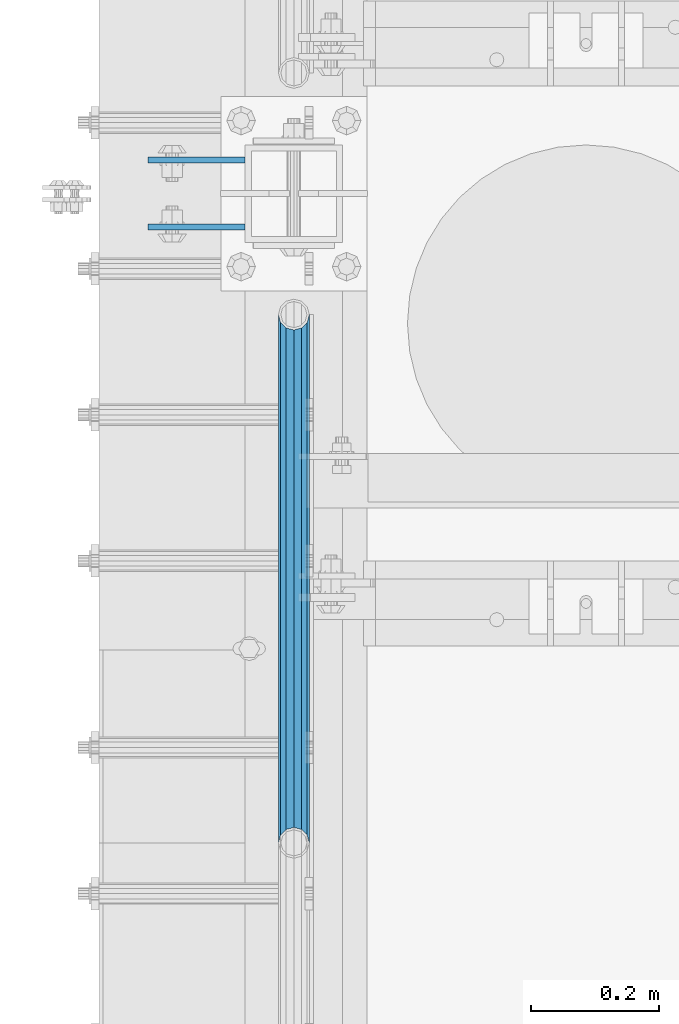
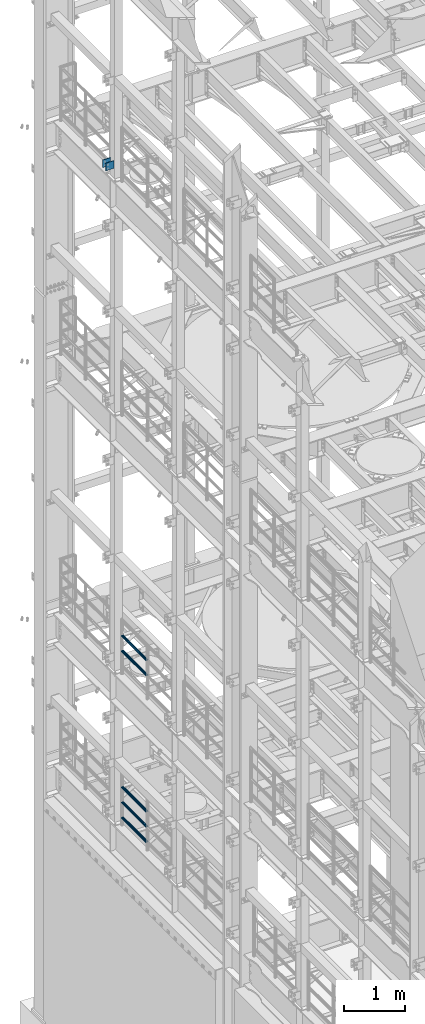
# One storey, part 1307 of 1876: 7 beams, 3 elements without a shape of their own.
"""IFC2X3 building model written with IfcOpenShell, lengths in millimetres."""

import ifcopenshell
import ifcopenshell.guid

model = None  # the IFC model being written
_history = None  # IfcOwnerHistory: only IFC2X3 demands one
_inside = {}  # id of a spatial element -> (the spatial element, [elements in it])
_under = {}  # id of a project, library or spatial element -> (it, [spatial elements below it])
_declared = {}  # id of a project -> (the project, [libraries it declares])
_typed = {}  # id of a type object -> (the type object, [elements of that type])
_made_of = {}  # id of a material, layer set ... -> (it, [elements and type objects made of it])


def new_model(schema):
    """Start an empty IFC model of exactly this schema.

    Asked for "IFC4X3", IfcOpenShell would pick the latest addendum, in which some entities
    have other attributes; the version numbers below select the first issue.
    IFC2X3 requires an IfcOwnerHistory on every rooted entity: one is made here for all.
    """
    global model, _history
    if schema == "IFC4X3":
        model = ifcopenshell.file(schema_version=(4, 3, 0, 0))
    else:
        model = ifcopenshell.file(schema=schema)
    _inside.clear()
    _under.clear()
    _declared.clear()
    _typed.clear()
    _made_of.clear()
    _history = None
    if model.schema == "IFC2X3":
        org = make("IfcOrganization", Name="unknown")
        user = make(
            "IfcPersonAndOrganization",
            ThePerson=make("IfcPerson", FamilyName="unknown"),
            TheOrganization=org,
        )
        app = make(
            "IfcApplication",
            ApplicationDeveloper=org,
            Version="unknown",
            ApplicationFullName="unknown",
            ApplicationIdentifier="unknown",
        )
        _history = make(
            "IfcOwnerHistory",
            OwningUser=user,
            OwningApplication=app,
            ChangeAction="ADDED",
            CreationDate=0,
        )
    return model


def make(cls, **values):
    """One entity of the class cls with the attributes given. An attribute that is None is left unset."""
    return model.create_entity(
        cls, **{name: value for name, value in values.items() if value is not None}
    )


def rooted(cls, **values):
    """An entity with a GlobalId (a new one), such as an element, a storey or a relation."""
    return make(cls, GlobalId=ifcopenshell.guid.new(), OwnerHistory=_history, **values)


def si_unit(unit_type, name, prefix=None):
    """IfcSIUnit, for example si_unit("LENGTHUNIT", "METRE", prefix="MILLI")."""
    return make("IfcSIUnit", UnitType=unit_type, Prefix=prefix, Name=name)


def assignment(units):
    """IfcUnitAssignment: the units of a project."""
    return None if units is None else make("IfcUnitAssignment", Units=units)


def point(xyz):
    """IfcCartesianPoint."""
    return None if xyz is None else make("IfcCartesianPoint", Coordinates=xyz)


def direction(xyz):
    """IfcDirection."""
    return None if xyz is None else make("IfcDirection", DirectionRatios=xyz)


def frame(location, z_axis=None, x_axis=None):
    """IfcAxis2Placement3D, a coordinate frame: its origin and axes. An axis left out is left unset."""
    return make(
        "IfcAxis2Placement3D",
        Location=point(location),
        Axis=direction(z_axis),
        RefDirection=direction(x_axis),
    )


def origin_with_axes():
    """The frame at (0, 0, 0) with the z axis (0, 0, 1) and the x axis (1, 0, 0) written out."""
    return frame((0.0, 0.0, 0.0), z_axis=(0.0, 0.0, 1.0), x_axis=(1.0, 0.0, 0.0))


def place(relative_to, where):
    """IfcLocalPlacement: puts the frame where relative to a parent placement (None: the world)."""
    return make(
        "IfcLocalPlacement", PlacementRelTo=relative_to, RelativePlacement=where
    )


def context(
    kind, dimensions, precision=None, world=None, true_north=None, identifier=None
):
    """IfcGeometricRepresentationContext, for example the 3D "Model" context."""
    return make(
        "IfcGeometricRepresentationContext",
        ContextIdentifier=identifier,
        ContextType=kind,
        CoordinateSpaceDimension=dimensions,
        Precision=precision,
        WorldCoordinateSystem=world,
        TrueNorth=true_north,
    )


def subcontext(parent, identifier, kind, view, scale=None):
    """IfcGeometricRepresentationSubContext, for example "Body" below "Model"."""
    return make(
        "IfcGeometricRepresentationSubContext",
        ContextIdentifier=identifier,
        ContextType=kind,
        ParentContext=parent,
        TargetScale=scale,
        TargetView=view,
    )


def project(units=None, contexts=None):
    """IfcProject with its units and contexts."""
    return rooted(
        "IfcProject",
        Name="project",
        RepresentationContexts=contexts,
        UnitsInContext=assignment(units),
    )


def spatial(cls, under=None, at=None, **own):
    """A site, building, storey or space (cls), placed at a placement, below another one or the project."""
    s = rooted(cls, ObjectPlacement=at, **own)
    if under is not None:
        _under.setdefault(under.id(), (under, []))[1].append(s)
    return s


def faces_of(points, faces, orient=None, outer=None):
    """IfcFace entities. A face is a list of loops; a loop is a list of indices into points, from 0.

    orient and outer hold one flag for each loop. By default every Orientation is true, the
    first loop of a face is its IfcFaceOuterBound and the others are IfcFaceBound.
    """
    made = []
    for i, loops in enumerate(faces):
        bounds = []
        for j, loop in enumerate(loops):
            is_outer = j == 0 if outer is None else outer[i][j]
            bounds.append(
                make(
                    "IfcFaceOuterBound" if is_outer else "IfcFaceBound",
                    Bound=make("IfcPolyLoop", Polygon=[points[k] for k in loop]),
                    Orientation=True if orient is None else orient[i][j],
                )
            )
        made.append(make("IfcFace", Bounds=bounds))
    return made


def faceted_brep(points, faces, orient=None, outer=None, voids=None):
    """IfcFacetedBrep: a solid bounded by flat faces; with voids (closed shells), ...WithVoids."""
    shared = [point(p) for p in points]
    hull = make("IfcClosedShell", CfsFaces=faces_of(shared, faces, orient, outer))
    if voids is None:
        return make("IfcFacetedBrep", Outer=hull)
    return make(
        "IfcFacetedBrepWithVoids",
        Outer=hull,
        Voids=[
            make(cls, CfsFaces=faces_of(shared, fs, o, b)) for cls, fs, o, b in voids
        ],
    )


def shape(context_of_items, identifier, shape_type, items):
    """IfcShapeRepresentation: the items that make up one representation, for example the "Body"."""
    return make(
        "IfcShapeRepresentation",
        ContextOfItems=context_of_items,
        RepresentationIdentifier=identifier,
        RepresentationType=shape_type,
        Items=items,
    )


def material(Name=None, Category=None):
    """IfcMaterial."""
    return make("IfcMaterial", Name=Name, Category=Category)


def made_of(thing, what):
    """Note that an element or type object is made of a material, layer set ...; save() writes the relation."""
    if what is not None:
        _made_of.setdefault(what.id(), (what, []))[1].append(thing)
    return thing


def type_object(cls, material=None, **own):
    """A type object (cls), such as IfcWallType, which elements share."""
    return made_of(rooted(cls, **own), material)


def element(
    cls,
    number,
    at=None,
    inside=None,
    cuts=None,
    type_object=None,
    material=None,
    context=None,
    identifier="Body",
    shape_type=None,
    held_by="IfcProductDefinitionShape",
    body=None,
    shapes=None,
    **own,
):
    """One element of the class cls, such as IfcWall. Its Tag is "e" and its number.

    at: its placement. inside: the storey or other place that contains it. cuts: it is an
    opening in that element (IfcRelVoidsElement). A single representation is given by context,
    identifier, shape_type and body (its items); several are given by shapes. held_by: the class
    of the entity that holds the representations. save() writes the other relations.
    """
    e = rooted(cls, Tag="e%d" % number, ObjectPlacement=at, **own)
    if body is not None:
        shapes = [shape(context, identifier, shape_type, body)]
    if shapes is not None:
        e.Representation = make(held_by, Representations=shapes)
    if inside is not None:
        _inside.setdefault(inside.id(), (inside, []))[1].append(e)
    if cuts is not None:
        rooted(
            "IfcRelVoidsElement", RelatingBuildingElement=cuts, RelatedOpeningElement=e
        )
    if type_object is not None:
        _typed.setdefault(type_object.id(), (type_object, []))[1].append(e)
    return made_of(e, material)


def aggregate(whole, parts):
    """IfcRelAggregates: a whole, such as a stair, and the parts it consists of."""
    return rooted("IfcRelAggregates", RelatingObject=whole, RelatedObjects=parts)


def save(model, path):
    """Write the relations noted so far, then the file.

    IfcRelAggregates (storeys below a building ...), IfcRelContainedInSpatialStructure (elements
    in a storey), IfcRelDefinesByType, IfcRelAssociatesMaterial and IfcRelDeclares: one each for
    every whole, place, type object, material and project.
    """
    for whole, parts in _under.values():
        aggregate(whole, parts)
    for where, things in _inside.values():
        rooted(
            "IfcRelContainedInSpatialStructure",
            RelatedElements=things,
            RelatingStructure=where,
        )
    for kind, things in _typed.values():
        rooted("IfcRelDefinesByType", RelatedObjects=things, RelatingType=kind)
    for what, things in _made_of.values():
        rooted("IfcRelAssociatesMaterial", RelatedObjects=things, RelatingMaterial=what)
    for by, libraries in _declared.values():
        rooted("IfcRelDeclares", RelatingContext=by, RelatedDefinitions=libraries)
    model.write(path)


model = new_model("IFC2X3")

# Units and contexts
model_context = context("Model", 3, precision=1e-05, world=origin_with_axes())
body_context = subcontext(model_context, "Body", "Model", "MODEL_VIEW")
ifc_project = project(units=[si_unit("LENGTHUNIT", "METRE", prefix="MILLI"), si_unit("AREAUNIT", "SQUARE_METRE"), si_unit("VOLUMEUNIT", "CUBIC_METRE"), si_unit("MASSUNIT", "GRAM", prefix="KILO"), si_unit("TIMEUNIT", "SECOND"), si_unit("PLANEANGLEUNIT", "RADIAN"), si_unit("SOLIDANGLEUNIT", "STERADIAN"), si_unit("THERMODYNAMICTEMPERATUREUNIT", "DEGREE_CELSIUS"), si_unit("LUMINOUSINTENSITYUNIT", "LUMEN")], contexts=[model_context])

# Site, building, storey
site_placement = place(None, origin_with_axes())
site = spatial("IfcSite", under=ifc_project, at=site_placement, CompositionType="ELEMENT")
building_placement = place(site_placement, origin_with_axes())
building = spatial("IfcBuilding", under=site, at=building_placement, Name="Undefined", CompositionType="ELEMENT")
storey_placement = place(building_placement, origin_with_axes())
storey = spatial("IfcBuildingStorey", under=building, at=storey_placement, Name="Undefined", CompositionType="ELEMENT", Elevation=0.0)

# Assembly, beams
assembly_1_placement = place(storey_placement, origin_with_axes())
assembly_1 = element("IfcElementAssembly", 1, at=assembly_1_placement, inside=storey, Name="BEAM", AssemblyPlace="NOTDEFINED", PredefinedType="RIGID_FRAME")
ifc_material_1 = material(Name="STEEL/A36")
beam_type_1 = type_object("IfcBeamType", PredefinedType="NOTDEFINED")
beam_1_placement = place(assembly_1_placement, frame((-76.2000002548894, 11736.3875, 18275.3), z_axis=(0.0, 0.0, -1.0), x_axis=(-1.0, 0.0, 0.0)))
beam_1 = element("IfcBeam", 2, at=beam_1_placement, type_object=beam_type_1, material=ifc_material_1, Name="PLATE", context=body_context, shape_type="Brep", body=[
    faceted_brep([(0.0, 4.76249999999982, -76.1999999999998), (3.63797880709171e-12, 4.76249999999982, 76.1999969482422), (152.399993896484, 4.76250000000073, 76.1999969482422), (152.4, 4.76249999999982, -76.1999999999998), (3.63797880709171e-12, -4.76249999999982, 76.1999969482422), (152.399993896484, -4.76250000000073, 76.1999969482422), (0.0, -4.76249999999982, -76.1999999999998), (152.4, -4.76249999999982, -76.1999999999998)], [[[0, 1, 2, 3]], [[4, 5, 2, 1]], [[4, 6, 7, 5]], [[6, 0, 3, 7]], [[5, 7, 3, 2]], [[6, 4, 1, 0]]]),
])
beam_2_placement = place(assembly_1_placement, frame((-76.2000002548894, 11631.6125, 18275.3), z_axis=(0.0, 0.0, -1.0), x_axis=(-1.0, 0.0, 0.0)))
beam_2 = element("IfcBeam", 3, at=beam_2_placement, type_object=beam_type_1, material=ifc_material_1, Name="PLATE", context=body_context, shape_type="Brep", body=[
    faceted_brep([(0.0, 4.76249999999982, -76.1999999999998), (3.63797880709171e-12, 4.76249999999982, 76.1999969482422), (152.399993896484, 4.76250000000073, 76.1999969482422), (152.4, 4.76249999999982, -76.1999999999998), (3.63797880709171e-12, -4.76249999999982, 76.1999969482422), (152.399993896484, -4.76250000000073, 76.1999969482422), (0.0, -4.76249999999982, -76.1999999999998), (152.4, -4.76249999999982, -76.1999999999998)], [[[0, 1, 2, 3]], [[4, 5, 2, 1]], [[4, 6, 7, 5]], [[6, 0, 3, 7]], [[5, 7, 3, 2]], [[6, 4, 1, 0]]]),
])
aggregate(assembly_1, [beam_1, beam_2])

assembly_2_placement = place(storey_placement, origin_with_axes())
assembly_2 = element("IfcElementAssembly", 4, at=assembly_2_placement, inside=storey, Name="RAIL", AssemblyPlace="NOTDEFINED", PredefinedType="RIGID_FRAME")
ifc_material_2 = material()
beam_type_2 = type_object("IfcBeamType", Name="PIPE1-1/2SCH40", PredefinedType="NOTDEFINED")
beam_3_placement = place(assembly_2_placement, frame((-1.81898940354586e-12, 10668.0, 8620.125), z_axis=(0.0, 0.0, -1.0), x_axis=(0.0, 1.0, 0.0)))
beam_3 = element("IfcBeam", 5, at=beam_3_placement, type_object=beam_type_2, material=ifc_material_2, Name="RAIL", ObjectType="PIPE1-1/2SCH40", context=body_context, shape_type="Brep", body=[
    faceted_brep([(0.0, 24.1299999999992, 0.0), (12.0650000000064, 20.8971929933177, -12.0649999999987), (12.0650000000064, 20.8971929933177, 12.0649999999987), (12.0650000000064, -20.8971929933177, 12.0649999999987), (12.0650000000064, -20.8971929933177, -12.0649999999987), (0.0, -24.1299999999992, 0.0), (20.8971929933249, -12.0650000000005, 20.8971929933177), (20.8971929933249, -12.0650000000005, 15.8661214311796), (15.2545715621445, -17.7076214311801, 10.2235000000001), (12.5151929933249, -20.4470000000001, 0.0), (15.2545715621445, -17.7076214311801, -10.2235000000001), (20.8971929933249, -12.0650000000005, -15.8661214311796), (20.8971929933249, -12.0650000000005, -20.8971929933177), (24.1300000000063, 0.0, -20.4470000000001), (24.1300000000063, 0.0, -24.130000000001), (21.3906214311868, -10.2235000000001, -17.7076214311819), (21.3906214311868, 10.2235000000001, -17.7076214311819), (20.8971929933249, 12.0650000000005, -15.8661214311796), (20.8971929933249, 12.0650000000005, -20.8971929933177), (15.2545715621445, 17.7076214311801, -10.2235000000001), (12.5151929933249, 20.4470000000001, 0.0), (15.2545715621445, 17.7076214311801, 10.2235000000001), (20.8971929933249, 12.0650000000005, 15.8661214311796), (20.8971929933249, 12.0650000000005, 20.8971929933177), (21.3906214311868, 10.2235000000001, 17.7076214311819), (24.1300000000064, 0.0, 20.4470000000001), (24.1300000000064, 0.0, 24.130000000001), (21.3906214311868, -10.2235000000001, 17.7076214311819), (826.77, 24.1300000000001, 0.0), (814.705, 20.8971929933186, -12.0649999999987), (805.872807006681, 12.0649999999996, -20.8971929933177), (826.77, -24.1300000000001, 0.0), (814.705, -20.8971929933186, -12.0649999999987), (814.705, -20.8971929933186, 12.0649999999987), (805.872807006681, -12.0649999999996, 20.8971929933177), (805.872807006681, -12.0649999999996, -20.8971929933177), (802.640000000001, 0.0, -24.130000000001), (805.379378568819, 10.2235000000001, -17.7076214311819), (802.640000000001, 0.0, -20.4470000000001), (805.872807006683, 12.0649999999996, -15.8661214311796), (805.872807006683, -12.0649999999996, -15.8661214311796), (805.379378568819, -10.2235000000001, -17.7076214311819), (811.515428437862, -17.7076214311801, -10.2235000000001), (814.254807006682, -20.4470000000001, 0.0), (811.515428437862, -17.7076214311801, 10.2235000000001), (805.872807006683, -12.0649999999996, 15.8661214311796), (805.379378568819, -10.2235000000001, 17.7076214311819), (802.640000000001, 0.0, 20.4470000000001), (802.640000000001, 0.0, 24.130000000001), (805.872807006681, 12.0649999999996, 20.8971929933177), (814.705, 20.8971929933186, 12.0649999999987), (805.872807006683, 12.0649999999996, 15.8661214311796), (811.515428437862, 17.7076214311801, 10.2235000000001), (814.254807006682, 20.4470000000001, 0.0), (811.515428437862, 17.7076214311801, -10.2235000000001), (805.379378568819, 10.2235000000001, 17.7076214311819)], [[[0, 1, 2]], [[3, 4, 5]], [[6, 7, 8, 9, 10, 11, 12, 4, 3]], [[13, 14, 12, 11, 15]], [[16, 17, 18, 14, 13]], [[2, 1, 18, 17, 19, 20, 21, 22, 23]], [[23, 22, 24, 25, 26]], [[26, 25, 27, 7, 6]], [[1, 0, 28, 29]], [[18, 1, 29, 30]], [[31, 32, 33]], [[6, 3, 33, 34]], [[3, 5, 31, 33]], [[5, 4, 32, 31]], [[4, 12, 35, 32]], [[12, 14, 36, 35]], [[14, 18, 30, 36]], [[37, 38, 36, 30, 39]], [[40, 35, 36, 38, 41]], [[33, 32, 35, 40, 42, 43, 44, 45, 34]], [[34, 45, 46, 47, 48]], [[26, 6, 34, 48]], [[2, 23, 49, 50]], [[23, 26, 48, 49]], [[0, 2, 50, 28]], [[28, 50, 29]], [[49, 51, 52, 53, 54, 39, 30, 29, 50]], [[48, 47, 55, 51, 49]], [[25, 24, 55, 47]], [[55, 24, 22, 21, 52, 51]], [[21, 20, 53, 52]], [[20, 19, 54, 53]], [[19, 17, 16, 37, 39, 54]], [[16, 13, 38, 37]], [[13, 15, 41, 38]], [[41, 15, 11, 10, 42, 40]], [[10, 9, 43, 42]], [[9, 8, 44, 43]], [[8, 7, 27, 46, 45, 44]], [[27, 25, 47, 46]]]),
])
beam_4_placement = place(assembly_2_placement, frame((-1.81898940354586e-12, 10668.0, 8924.925), z_axis=(0.0, 0.0, -1.0), x_axis=(0.0, 1.0, 0.0)))
beam_4 = element("IfcBeam", 6, at=beam_4_placement, type_object=beam_type_2, material=ifc_material_2, Name="RAIL", ObjectType="PIPE1-1/2SCH40", context=body_context, shape_type="Brep", body=[
    faceted_brep([(0.0, 24.1299999999992, 0.0), (12.0650000000064, 20.8971929933177, -12.0649999999987), (12.0650000000064, 20.8971929933177, 12.0649999999987), (12.0650000000064, -20.8971929933177, 12.0649999999987), (12.0650000000064, -20.8971929933177, -12.0649999999987), (0.0, -24.1299999999992, 0.0), (20.8971929933249, -12.0650000000005, 20.8971929933177), (20.8971929933249, -12.0650000000005, 15.8661214311796), (15.2545715621445, -17.7076214311801, 10.2235000000001), (12.5151929933249, -20.4470000000001, 0.0), (15.2545715621445, -17.7076214311801, -10.2235000000001), (20.8971929933249, -12.0650000000005, -15.8661214311796), (20.8971929933249, -12.0650000000005, -20.8971929933177), (24.1300000000063, 0.0, -20.4470000000001), (24.1300000000063, 0.0, -24.130000000001), (21.3906214311868, -10.2235000000001, -17.7076214311819), (21.3906214311868, 10.2235000000001, -17.7076214311819), (20.8971929933249, 12.0650000000005, -15.8661214311796), (20.8971929933249, 12.0650000000005, -20.8971929933177), (15.2545715621445, 17.7076214311801, -10.2235000000001), (12.5151929933249, 20.4470000000001, 0.0), (15.2545715621445, 17.7076214311801, 10.2235000000001), (20.8971929933249, 12.0650000000005, 15.8661214311796), (20.8971929933249, 12.0650000000005, 20.8971929933177), (21.3906214311868, 10.2235000000001, 17.7076214311819), (24.1300000000064, 0.0, 20.4470000000001), (24.1300000000064, 0.0, 24.130000000001), (21.3906214311868, -10.2235000000001, 17.7076214311819), (826.77, 24.1300000000001, 0.0), (814.705, 20.8971929933186, -12.0649999999987), (805.872807006681, 12.0649999999996, -20.8971929933177), (826.77, -24.1300000000001, 0.0), (814.705, -20.8971929933186, -12.0649999999987), (814.705, -20.8971929933186, 12.0649999999987), (805.872807006681, -12.0649999999996, 20.8971929933177), (805.872807006681, -12.0649999999996, -20.8971929933177), (802.640000000001, 0.0, -24.130000000001), (805.379378568819, 10.2235000000001, -17.7076214311819), (802.640000000001, 0.0, -20.4470000000001), (805.872807006683, 12.0649999999996, -15.8661214311796), (805.872807006683, -12.0649999999996, -15.8661214311796), (805.379378568819, -10.2235000000001, -17.7076214311819), (811.515428437862, -17.7076214311801, -10.2235000000001), (814.254807006682, -20.4470000000001, 0.0), (811.515428437862, -17.7076214311801, 10.2235000000001), (805.872807006683, -12.0649999999996, 15.8661214311796), (805.379378568819, -10.2235000000001, 17.7076214311819), (802.640000000001, 0.0, 20.4470000000001), (802.640000000001, 0.0, 24.130000000001), (805.872807006681, 12.0649999999996, 20.8971929933177), (814.705, 20.8971929933186, 12.0649999999987), (805.872807006683, 12.0649999999996, 15.8661214311796), (811.515428437862, 17.7076214311801, 10.2235000000001), (814.254807006682, 20.4470000000001, 0.0), (811.515428437862, 17.7076214311801, -10.2235000000001), (805.379378568819, 10.2235000000001, 17.7076214311819)], [[[0, 1, 2]], [[3, 4, 5]], [[6, 7, 8, 9, 10, 11, 12, 4, 3]], [[13, 14, 12, 11, 15]], [[16, 17, 18, 14, 13]], [[2, 1, 18, 17, 19, 20, 21, 22, 23]], [[23, 22, 24, 25, 26]], [[26, 25, 27, 7, 6]], [[1, 0, 28, 29]], [[18, 1, 29, 30]], [[31, 32, 33]], [[6, 3, 33, 34]], [[3, 5, 31, 33]], [[5, 4, 32, 31]], [[4, 12, 35, 32]], [[12, 14, 36, 35]], [[14, 18, 30, 36]], [[37, 38, 36, 30, 39]], [[40, 35, 36, 38, 41]], [[33, 32, 35, 40, 42, 43, 44, 45, 34]], [[34, 45, 46, 47, 48]], [[26, 6, 34, 48]], [[2, 23, 49, 50]], [[23, 26, 48, 49]], [[0, 2, 50, 28]], [[28, 50, 29]], [[49, 51, 52, 53, 54, 39, 30, 29, 50]], [[48, 47, 55, 51, 49]], [[25, 24, 55, 47]], [[55, 24, 22, 21, 52, 51]], [[21, 20, 53, 52]], [[20, 19, 54, 53]], [[19, 17, 16, 37, 39, 54]], [[16, 13, 38, 37]], [[13, 15, 41, 38]], [[41, 15, 11, 10, 42, 40]], [[10, 9, 43, 42]], [[9, 8, 44, 43]], [[8, 7, 27, 46, 45, 44]], [[27, 25, 47, 46]]]),
])
aggregate(assembly_2, [beam_3, beam_4])

assembly_3_placement = place(storey_placement, origin_with_axes())
assembly_3 = element("IfcElementAssembly", 7, at=assembly_3_placement, inside=storey, Name="RAIL", AssemblyPlace="NOTDEFINED", PredefinedType="RIGID_FRAME")
beam_5_placement = place(assembly_3_placement, frame((-1.81898940354586e-12, 11494.77, 5292.725), z_axis=(0.0, 0.0, 1.0), x_axis=(0.0, -1.0, 0.0)))
beam_5 = element("IfcBeam", 8, at=beam_5_placement, type_object=beam_type_2, material=ifc_material_2, Name="RAIL", ObjectType="PIPE1-1/2SCH40", context=body_context, shape_type="Brep", body=[
    faceted_brep([(805.872807006681, -12.0649999999996, 20.8971929933177), (805.872807006683, -12.0649999999996, 15.8661214311796), (805.379378568819, -10.2235000000001, 17.7076214311819), (802.640000000001, 0.0, 20.4470000000001), (802.640000000001, 0.0, 24.130000000001), (805.379378568819, 10.2235000000001, 17.7076214311819), (805.872807006683, 12.0649999999996, 15.8661214311796), (805.872807006681, 12.0649999999996, 20.8971929933177), (826.77, 24.1300000000001, 0.0), (814.705, 20.8971929933186, 12.0649999999987), (814.705, 20.8971929933186, -12.0649999999987), (811.515428437862, 17.7076214311801, 10.2235000000001), (814.254807006682, 20.4470000000001, 0.0), (811.515428437862, 17.7076214311801, -10.2235000000001), (805.872807006683, 12.0649999999996, -15.8661214311796), (805.872807006681, 12.0649999999996, -20.8971929933177), (805.379378568819, 10.2235000000001, -17.7076214311819), (802.640000000001, 0.0, -20.4470000000001), (802.640000000001, 0.0, -24.130000000001), (805.872807006683, -12.0649999999996, -15.8661214311796), (805.872807006681, -12.0649999999996, -20.8971929933177), (805.379378568819, -10.2235000000001, -17.7076214311819), (826.77, -24.1300000000001, 0.0), (814.705, -20.8971929933186, -12.0649999999987), (814.705, -20.8971929933186, 12.0649999999987), (811.515428437862, -17.7076214311801, -10.2235000000001), (814.254807006682, -20.4470000000001, 0.0), (811.515428437862, -17.7076214311801, 10.2235000000001), (12.0650000000064, -20.8971929933177, -12.0649999999987), (20.8971929933249, -12.0650000000005, -20.8971929933177), (0.0, 24.1299999999992, 0.0), (12.0650000000064, 20.8971929933177, -12.0649999999987), (12.0650000000064, 20.8971929933177, 12.0649999999987), (20.8971929933249, 12.0650000000005, 20.8971929933177), (24.1300000000064, 0.0, 24.130000000001), (20.8971929933249, 12.0650000000005, -20.8971929933177), (24.1300000000063, 0.0, -24.130000000001), (24.1300000000063, 0.0, -20.4470000000001), (20.8971929933249, -12.0650000000005, -15.8661214311796), (21.3906214311868, -10.2235000000001, -17.7076214311819), (21.3906214311868, 10.2235000000001, -17.7076214311819), (20.8971929933249, 12.0650000000005, -15.8661214311796), (15.2545715621445, 17.7076214311801, -10.2235000000001), (12.5151929933249, 20.4470000000001, 0.0), (15.2545715621445, 17.7076214311801, 10.2235000000001), (20.8971929933249, 12.0650000000005, 15.8661214311796), (21.3906214311868, 10.2235000000001, 17.7076214311819), (24.1300000000064, 0.0, 20.4470000000001), (21.3906214311868, -10.2235000000001, 17.7076214311819), (20.8971929933249, -12.0650000000005, 15.8661214311796), (20.8971929933249, -12.0650000000005, 20.8971929933177), (12.0650000000064, -20.8971929933177, 12.0649999999987), (0.0, -24.1299999999992, 0.0), (15.2545715621445, -17.7076214311801, 10.2235000000001), (12.5151929933249, -20.4470000000001, 0.0), (15.2545715621445, -17.7076214311801, -10.2235000000001)], [[[0, 1, 2, 3, 4]], [[4, 3, 5, 6, 7]], [[8, 9, 10]], [[7, 6, 11, 12, 13, 14, 15, 10, 9]], [[16, 17, 18, 15, 14]], [[19, 20, 18, 17, 21]], [[22, 23, 24]], [[24, 23, 20, 19, 25, 26, 27, 1, 0]], [[28, 29, 20, 23]], [[30, 31, 32]], [[33, 34, 4, 7]], [[32, 33, 7, 9]], [[30, 32, 9, 8]], [[31, 30, 8, 10]], [[35, 31, 10, 15]], [[36, 35, 15, 18]], [[29, 36, 18, 20]], [[37, 36, 29, 38, 39]], [[40, 41, 35, 36, 37]], [[32, 31, 35, 41, 42, 43, 44, 45, 33]], [[33, 45, 46, 47, 34]], [[34, 47, 48, 49, 50]], [[34, 50, 0, 4]], [[50, 51, 24, 0]], [[51, 52, 22, 24]], [[52, 28, 23, 22]], [[51, 28, 52]], [[50, 49, 53, 54, 55, 38, 29, 28, 51]], [[55, 54, 26, 25]], [[21, 39, 38, 55, 25, 19]], [[37, 39, 21, 17]], [[40, 37, 17, 16]], [[42, 41, 40, 16, 14, 13]], [[43, 42, 13, 12]], [[44, 43, 12, 11]], [[5, 46, 45, 44, 11, 6]], [[47, 46, 5, 3]], [[48, 47, 3, 2]], [[53, 49, 48, 2, 1, 27]], [[54, 53, 27, 26]]]),
])
beam_6_placement = place(assembly_3_placement, frame((-1.81898940354586e-12, 10668.0, 5597.525), z_axis=(0.0, 0.0, -1.0), x_axis=(0.0, 1.0, 0.0)))
beam_6 = element("IfcBeam", 9, at=beam_6_placement, type_object=beam_type_2, material=ifc_material_2, Name="RAIL", ObjectType="PIPE1-1/2SCH40", context=body_context, shape_type="Brep", body=[
    faceted_brep([(0.0, 24.1299999999992, 0.0), (12.0650000000064, 20.8971929933177, -12.0649999999987), (12.0650000000064, 20.8971929933177, 12.0649999999987), (12.0650000000064, -20.8971929933177, 12.0649999999987), (12.0650000000064, -20.8971929933177, -12.0649999999987), (0.0, -24.1299999999992, 0.0), (20.8971929933249, -12.0650000000005, 20.8971929933177), (20.8971929933249, -12.0650000000005, 15.8661214311796), (15.2545715621445, -17.7076214311801, 10.2235000000001), (12.5151929933249, -20.4470000000001, 0.0), (15.2545715621445, -17.7076214311801, -10.2235000000001), (20.8971929933249, -12.0650000000005, -15.8661214311796), (20.8971929933249, -12.0650000000005, -20.8971929933177), (24.1300000000063, 0.0, -20.4470000000001), (24.1300000000063, 0.0, -24.130000000001), (21.3906214311868, -10.2235000000001, -17.7076214311819), (21.3906214311868, 10.2235000000001, -17.7076214311819), (20.8971929933249, 12.0650000000005, -15.8661214311796), (20.8971929933249, 12.0650000000005, -20.8971929933177), (15.2545715621445, 17.7076214311801, -10.2235000000001), (12.5151929933249, 20.4470000000001, 0.0), (15.2545715621445, 17.7076214311801, 10.2235000000001), (20.8971929933249, 12.0650000000005, 15.8661214311796), (20.8971929933249, 12.0650000000005, 20.8971929933177), (21.3906214311868, 10.2235000000001, 17.7076214311819), (24.1300000000064, 0.0, 20.4470000000001), (24.1300000000064, 0.0, 24.130000000001), (21.3906214311868, -10.2235000000001, 17.7076214311819), (826.77, 24.1300000000001, 0.0), (814.705, 20.8971929933186, -12.0649999999987), (805.872807006681, 12.0649999999996, -20.8971929933177), (826.77, -24.1300000000001, 0.0), (814.705, -20.8971929933186, -12.0649999999987), (814.705, -20.8971929933186, 12.0649999999987), (805.872807006681, -12.0649999999996, 20.8971929933177), (805.872807006681, -12.0649999999996, -20.8971929933177), (802.640000000001, 0.0, -24.130000000001), (805.379378568819, 10.2235000000001, -17.7076214311819), (802.640000000001, 0.0, -20.4470000000001), (805.872807006683, 12.0649999999996, -15.8661214311796), (805.872807006683, -12.0649999999996, -15.8661214311796), (805.379378568819, -10.2235000000001, -17.7076214311819), (811.515428437862, -17.7076214311801, -10.2235000000001), (814.254807006682, -20.4470000000001, 0.0), (811.515428437862, -17.7076214311801, 10.2235000000001), (805.872807006683, -12.0649999999996, 15.8661214311796), (805.379378568819, -10.2235000000001, 17.7076214311819), (802.640000000001, 0.0, 20.4470000000001), (802.640000000001, 0.0, 24.130000000001), (805.872807006681, 12.0649999999996, 20.8971929933177), (814.705, 20.8971929933186, 12.0649999999987), (805.872807006683, 12.0649999999996, 15.8661214311796), (811.515428437862, 17.7076214311801, 10.2235000000001), (814.254807006682, 20.4470000000001, 0.0), (811.515428437862, 17.7076214311801, -10.2235000000001), (805.379378568819, 10.2235000000001, 17.7076214311819)], [[[0, 1, 2]], [[3, 4, 5]], [[6, 7, 8, 9, 10, 11, 12, 4, 3]], [[13, 14, 12, 11, 15]], [[16, 17, 18, 14, 13]], [[2, 1, 18, 17, 19, 20, 21, 22, 23]], [[23, 22, 24, 25, 26]], [[26, 25, 27, 7, 6]], [[1, 0, 28, 29]], [[18, 1, 29, 30]], [[31, 32, 33]], [[6, 3, 33, 34]], [[3, 5, 31, 33]], [[5, 4, 32, 31]], [[4, 12, 35, 32]], [[12, 14, 36, 35]], [[14, 18, 30, 36]], [[37, 38, 36, 30, 39]], [[40, 35, 36, 38, 41]], [[33, 32, 35, 40, 42, 43, 44, 45, 34]], [[34, 45, 46, 47, 48]], [[26, 6, 34, 48]], [[2, 23, 49, 50]], [[23, 26, 48, 49]], [[0, 2, 50, 28]], [[28, 50, 29]], [[49, 51, 52, 53, 54, 39, 30, 29, 50]], [[48, 47, 55, 51, 49]], [[25, 24, 55, 47]], [[55, 24, 22, 21, 52, 51]], [[21, 20, 53, 52]], [[20, 19, 54, 53]], [[19, 17, 16, 37, 39, 54]], [[16, 13, 38, 37]], [[13, 15, 41, 38]], [[41, 15, 11, 10, 42, 40]], [[10, 9, 43, 42]], [[9, 8, 44, 43]], [[8, 7, 27, 46, 45, 44]], [[27, 25, 47, 46]]]),
])
beam_7_placement = place(assembly_3_placement, frame((-1.81898940354586e-12, 10668.0, 5902.325), z_axis=(0.0, 0.0, -1.0), x_axis=(0.0, 1.0, 0.0)))
beam_7 = element("IfcBeam", 10, at=beam_7_placement, type_object=beam_type_2, material=ifc_material_2, Name="RAIL", ObjectType="PIPE1-1/2SCH40", context=body_context, shape_type="Brep", body=[
    faceted_brep([(0.0, 24.1299999999992, 0.0), (12.0650000000064, 20.8971929933177, -12.0649999999987), (12.0650000000064, 20.8971929933177, 12.0649999999987), (12.0650000000064, -20.8971929933177, 12.0649999999987), (12.0650000000064, -20.8971929933177, -12.0649999999987), (0.0, -24.1299999999992, 0.0), (20.8971929933249, -12.0650000000005, 20.8971929933177), (20.8971929933249, -12.0650000000005, 15.8661214311796), (15.2545715621445, -17.7076214311801, 10.2235000000001), (12.5151929933249, -20.4470000000001, 0.0), (15.2545715621445, -17.7076214311801, -10.2235000000001), (20.8971929933249, -12.0650000000005, -15.8661214311796), (20.8971929933249, -12.0650000000005, -20.8971929933177), (24.1300000000063, 0.0, -20.4470000000001), (24.1300000000063, 0.0, -24.130000000001), (21.3906214311868, -10.2235000000001, -17.7076214311819), (21.3906214311868, 10.2235000000001, -17.7076214311819), (20.8971929933249, 12.0650000000005, -15.8661214311796), (20.8971929933249, 12.0650000000005, -20.8971929933177), (15.2545715621445, 17.7076214311801, -10.2235000000001), (12.5151929933249, 20.4470000000001, 0.0), (15.2545715621445, 17.7076214311801, 10.2235000000001), (20.8971929933249, 12.0650000000005, 15.8661214311796), (20.8971929933249, 12.0650000000005, 20.8971929933177), (21.3906214311868, 10.2235000000001, 17.7076214311819), (24.1300000000064, 0.0, 20.4470000000001), (24.1300000000064, 0.0, 24.130000000001), (21.3906214311868, -10.2235000000001, 17.7076214311819), (826.77, 24.1300000000001, 0.0), (814.705, 20.8971929933186, -12.0649999999987), (805.872807006681, 12.0649999999996, -20.8971929933177), (826.77, -24.1300000000001, 0.0), (814.705, -20.8971929933186, -12.0649999999987), (814.705, -20.8971929933186, 12.0649999999987), (805.872807006681, -12.0649999999996, 20.8971929933177), (805.872807006681, -12.0649999999996, -20.8971929933177), (802.640000000001, 0.0, -24.130000000001), (805.379378568819, 10.2235000000001, -17.7076214311819), (802.640000000001, 0.0, -20.4470000000001), (805.872807006683, 12.0649999999996, -15.8661214311796), (805.872807006683, -12.0649999999996, -15.8661214311796), (805.379378568819, -10.2235000000001, -17.7076214311819), (811.515428437862, -17.7076214311801, -10.2235000000001), (814.254807006682, -20.4470000000001, 0.0), (811.515428437862, -17.7076214311801, 10.2235000000001), (805.872807006683, -12.0649999999996, 15.8661214311796), (805.379378568819, -10.2235000000001, 17.7076214311819), (802.640000000001, 0.0, 20.4470000000001), (802.640000000001, 0.0, 24.130000000001), (805.872807006681, 12.0649999999996, 20.8971929933177), (814.705, 20.8971929933186, 12.0649999999987), (805.872807006683, 12.0649999999996, 15.8661214311796), (811.515428437862, 17.7076214311801, 10.2235000000001), (814.254807006682, 20.4470000000001, 0.0), (811.515428437862, 17.7076214311801, -10.2235000000001), (805.379378568819, 10.2235000000001, 17.7076214311819)], [[[0, 1, 2]], [[3, 4, 5]], [[6, 7, 8, 9, 10, 11, 12, 4, 3]], [[13, 14, 12, 11, 15]], [[16, 17, 18, 14, 13]], [[2, 1, 18, 17, 19, 20, 21, 22, 23]], [[23, 22, 24, 25, 26]], [[26, 25, 27, 7, 6]], [[1, 0, 28, 29]], [[18, 1, 29, 30]], [[31, 32, 33]], [[6, 3, 33, 34]], [[3, 5, 31, 33]], [[5, 4, 32, 31]], [[4, 12, 35, 32]], [[12, 14, 36, 35]], [[14, 18, 30, 36]], [[37, 38, 36, 30, 39]], [[40, 35, 36, 38, 41]], [[33, 32, 35, 40, 42, 43, 44, 45, 34]], [[34, 45, 46, 47, 48]], [[26, 6, 34, 48]], [[2, 23, 49, 50]], [[23, 26, 48, 49]], [[0, 2, 50, 28]], [[28, 50, 29]], [[49, 51, 52, 53, 54, 39, 30, 29, 50]], [[48, 47, 55, 51, 49]], [[25, 24, 55, 47]], [[55, 24, 22, 21, 52, 51]], [[21, 20, 53, 52]], [[20, 19, 54, 53]], [[19, 17, 16, 37, 39, 54]], [[16, 13, 38, 37]], [[13, 15, 41, 38]], [[41, 15, 11, 10, 42, 40]], [[10, 9, 43, 42]], [[9, 8, 44, 43]], [[8, 7, 27, 46, 45, 44]], [[27, 25, 47, 46]]]),
])
aggregate(assembly_3, [beam_5, beam_6, beam_7])

save(model, "model.ifc")
